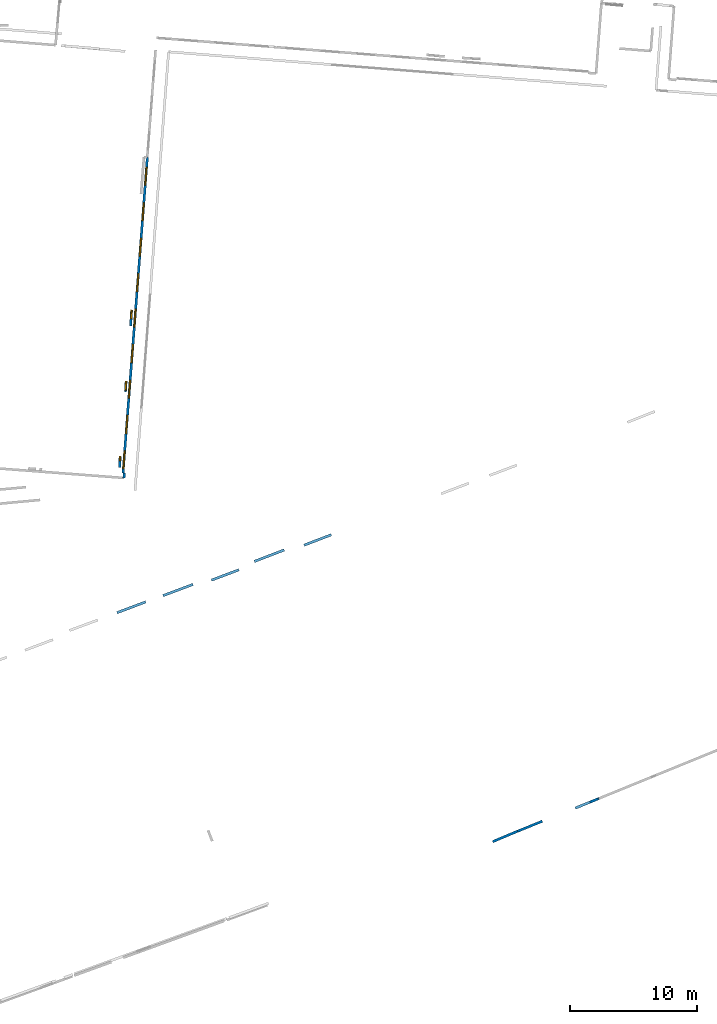
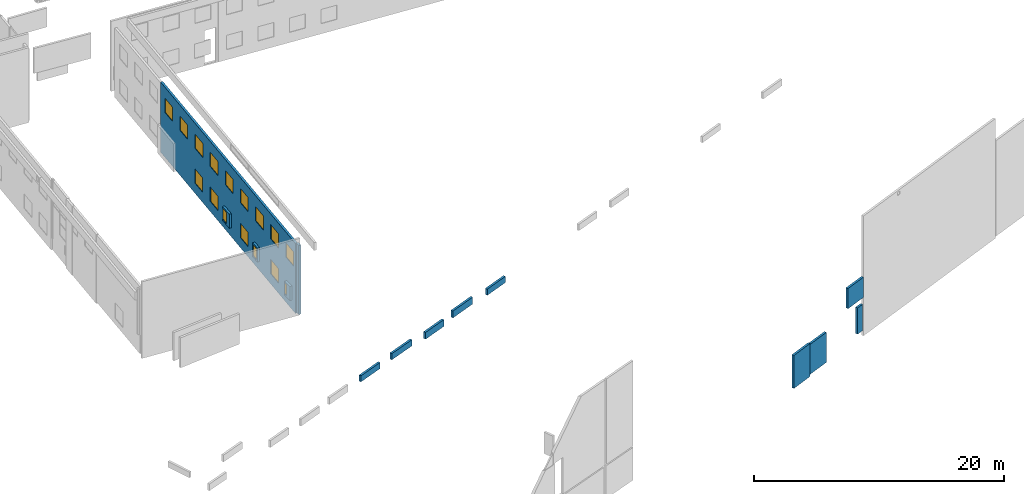
# One storey, part 2 of 27: 16 windows, 14 walls, 16 openings.
"""IFC2X3 building model written with IfcOpenShell, lengths in metres."""

import ifcopenshell
import ifcopenshell.guid

model = None  # the IFC model being written
_history = None  # IfcOwnerHistory: only IFC2X3 demands one
_inside = {}  # id of a spatial element -> (the spatial element, [elements in it])
_under = {}  # id of a project, library or spatial element -> (it, [spatial elements below it])
_declared = {}  # id of a project -> (the project, [libraries it declares])
_typed = {}  # id of a type object -> (the type object, [elements of that type])
_made_of = {}  # id of a material, layer set ... -> (it, [elements and type objects made of it])


def new_model(schema):
    """Start an empty IFC model of exactly this schema.

    Asked for "IFC4X3", IfcOpenShell would pick the latest addendum, in which some entities
    have other attributes; the version numbers below select the first issue.
    IFC2X3 requires an IfcOwnerHistory on every rooted entity: one is made here for all.
    """
    global model, _history
    if schema == "IFC4X3":
        model = ifcopenshell.file(schema_version=(4, 3, 0, 0))
    else:
        model = ifcopenshell.file(schema=schema)
    _inside.clear()
    _under.clear()
    _declared.clear()
    _typed.clear()
    _made_of.clear()
    _history = None
    if model.schema == "IFC2X3":
        org = make("IfcOrganization", Name="unknown")
        user = make(
            "IfcPersonAndOrganization",
            ThePerson=make("IfcPerson", FamilyName="unknown"),
            TheOrganization=org,
        )
        app = make(
            "IfcApplication",
            ApplicationDeveloper=org,
            Version="unknown",
            ApplicationFullName="unknown",
            ApplicationIdentifier="unknown",
        )
        _history = make(
            "IfcOwnerHistory",
            OwningUser=user,
            OwningApplication=app,
            ChangeAction="ADDED",
            CreationDate=0,
        )
    return model


def make(cls, **values):
    """One entity of the class cls with the attributes given. An attribute that is None is left unset."""
    return model.create_entity(
        cls, **{name: value for name, value in values.items() if value is not None}
    )


def entity(cls, *values):
    """Any entity or typed value of the class cls, its attributes in the order of the schema. None: left unset."""
    e = model.create_entity(cls)
    for i, value in enumerate(values):
        if value is not None:
            e[i] = value
    return e


def rooted(cls, **values):
    """An entity with a GlobalId (a new one), such as an element, a storey or a relation."""
    return make(cls, GlobalId=ifcopenshell.guid.new(), OwnerHistory=_history, **values)


def si_unit(unit_type, name, prefix=None):
    """IfcSIUnit, for example si_unit("LENGTHUNIT", "METRE", prefix="MILLI")."""
    return make("IfcSIUnit", UnitType=unit_type, Prefix=prefix, Name=name)


def converted_unit(unit_type, name, factor, base, dimensions=None, offset=None):
    """IfcConversionBasedUnit, such as the inch: factor (a typed value) times the base unit."""
    return make(
        "IfcConversionBasedUnit"
        if offset is None
        else "IfcConversionBasedUnitWithOffset",
        ConversionOffset=offset,
        Dimensions=None
        if dimensions is None
        else entity("IfcDimensionalExponents", *dimensions),
        UnitType=unit_type,
        Name=name,
        ConversionFactor=make(
            "IfcMeasureWithUnit", ValueComponent=factor, UnitComponent=base
        ),
    )


def derived_unit(unit_type, elements):
    """IfcDerivedUnit: a product of units, each with its exponent."""
    return make(
        "IfcDerivedUnit",
        Elements=[
            make("IfcDerivedUnitElement", Unit=unit, Exponent=power)
            for unit, power in elements
        ],
        UnitType=unit_type,
    )


def assignment(units):
    """IfcUnitAssignment: the units of a project."""
    return None if units is None else make("IfcUnitAssignment", Units=units)


def point(xyz):
    """IfcCartesianPoint."""
    return None if xyz is None else make("IfcCartesianPoint", Coordinates=xyz)


def direction(xyz):
    """IfcDirection."""
    return None if xyz is None else make("IfcDirection", DirectionRatios=xyz)


def frame(location, z_axis=None, x_axis=None):
    """IfcAxis2Placement3D, a coordinate frame: its origin and axes. An axis left out is left unset."""
    return make(
        "IfcAxis2Placement3D",
        Location=point(location),
        Axis=direction(z_axis),
        RefDirection=direction(x_axis),
    )


def frame_2d(location, x_axis=None):
    """IfcAxis2Placement2D, a coordinate frame in the plane: its origin and x axis."""
    return make(
        "IfcAxis2Placement2D", Location=point(location), RefDirection=direction(x_axis)
    )


def origin():
    """The frame at (0, 0, 0) with its axes left unset."""
    return frame((0.0, 0.0, 0.0))


def origin_2d_with_axis():
    """The frame at (0, 0) in the plane with the x axis (1, 0) written out."""
    return frame_2d((0.0, 0.0), x_axis=(1.0, 0.0))


def place(relative_to, where):
    """IfcLocalPlacement: puts the frame where relative to a parent placement (None: the world)."""
    return make(
        "IfcLocalPlacement", PlacementRelTo=relative_to, RelativePlacement=where
    )


def context(
    kind, dimensions, precision=None, world=None, true_north=None, identifier=None
):
    """IfcGeometricRepresentationContext, for example the 3D "Model" context."""
    return make(
        "IfcGeometricRepresentationContext",
        ContextIdentifier=identifier,
        ContextType=kind,
        CoordinateSpaceDimension=dimensions,
        Precision=precision,
        WorldCoordinateSystem=world,
        TrueNorth=true_north,
    )


def subcontext(parent, identifier, kind, view, scale=None):
    """IfcGeometricRepresentationSubContext, for example "Body" below "Model"."""
    return make(
        "IfcGeometricRepresentationSubContext",
        ContextIdentifier=identifier,
        ContextType=kind,
        ParentContext=parent,
        TargetScale=scale,
        TargetView=view,
    )


def project(units=None, contexts=None):
    """IfcProject with its units and contexts."""
    return rooted(
        "IfcProject",
        Name="project",
        RepresentationContexts=contexts,
        UnitsInContext=assignment(units),
    )


def spatial(cls, under=None, at=None, **own):
    """A site, building, storey or space (cls), placed at a placement, below another one or the project."""
    s = rooted(cls, ObjectPlacement=at, **own)
    if under is not None:
        _under.setdefault(under.id(), (under, []))[1].append(s)
    return s


def polyline(points):
    """IfcPolyline through the points."""
    return make("IfcPolyline", Points=[point(p) for p in points])


def profile(cls, at=None, kind="AREA", **sizes):
    """A parametric profile (cls). Its sizes go by their IFC names, for example OverallWidth=200.0."""
    return make(cls, ProfileType=kind, Position=at, **sizes)


def rectangle(**sizes):
    """IfcRectangleProfileDef."""
    return profile("IfcRectangleProfileDef", **sizes)


def outline(outer, holes=None, kind="AREA"):
    """IfcArbitraryClosedProfileDef: a profile drawn as a closed curve; with holes, ...WithVoids."""
    if holes is None:
        return make("IfcArbitraryClosedProfileDef", ProfileType=kind, OuterCurve=outer)
    return make(
        "IfcArbitraryProfileDefWithVoids",
        ProfileType=kind,
        OuterCurve=outer,
        InnerCurves=holes,
    )


def extrude(swept, where, along, depth):
    """IfcExtrudedAreaSolid: the profile swept, set in the frame where, extruded along a direction by depth."""
    return make(
        "IfcExtrudedAreaSolid",
        SweptArea=swept,
        Position=where,
        ExtrudedDirection=direction(along),
        Depth=depth,
    )


def shape(context_of_items, identifier, shape_type, items):
    """IfcShapeRepresentation: the items that make up one representation, for example the "Body"."""
    return make(
        "IfcShapeRepresentation",
        ContextOfItems=context_of_items,
        RepresentationIdentifier=identifier,
        RepresentationType=shape_type,
        Items=items,
    )


def source(mapping_origin, context_of_items, identifier, shape_type, items):
    """IfcRepresentationMap: a shape defined once, which mapped items show again and again."""
    return make(
        "IfcRepresentationMap",
        MappingOrigin=mapping_origin,
        MappedRepresentation=shape(context_of_items, identifier, shape_type, items),
    )


def transform(
    local_origin,
    x_axis=None,
    y_axis=None,
    z_axis=None,
    scale=None,
    scale2=None,
    scale3=None,
    uniform=True,
):
    """IfcCartesianTransformationOperator3D, or its non-uniform kind. x_axis, y_axis, z_axis: its Axis1, 2, 3."""
    if uniform:
        return make(
            "IfcCartesianTransformationOperator3D",
            Axis1=direction(x_axis),
            Axis2=direction(y_axis),
            LocalOrigin=point(local_origin),
            Scale=scale,
            Axis3=direction(z_axis),
        )
    return make(
        "IfcCartesianTransformationOperator3DnonUniform",
        Axis1=direction(x_axis),
        Axis2=direction(y_axis),
        LocalOrigin=point(local_origin),
        Scale=scale,
        Axis3=direction(z_axis),
        Scale2=scale2,
        Scale3=scale3,
    )


def mapped(mapping_source, mapping_target):
    """IfcMappedItem: shows the shape of a source again, moved by a transform."""
    return make(
        "IfcMappedItem", MappingSource=mapping_source, MappingTarget=mapping_target
    )


def material(Name=None, Category=None):
    """IfcMaterial."""
    return make("IfcMaterial", Name=Name, Category=Category)


def layer(
    of_material, thickness, ventilated=None, Name=None, Category=None, Priority=None
):
    """IfcMaterialLayer: one layer of a wall or slab, of a material (None: an air gap)."""
    return make(
        "IfcMaterialLayer",
        Material=of_material,
        LayerThickness=thickness,
        IsVentilated=ventilated,
        Name=Name,
        Category=Category,
        Priority=Priority,
    )


def layer_set(layers, Name=None):
    """IfcMaterialLayerSet."""
    return make("IfcMaterialLayerSet", MaterialLayers=layers, LayerSetName=Name)


def layer_usage(for_layer_set, set_direction, sense, offset, extent=None):
    """IfcMaterialLayerSetUsage: how a layer set lies in its element."""
    return make(
        "IfcMaterialLayerSetUsage",
        ForLayerSet=for_layer_set,
        LayerSetDirection=set_direction,
        DirectionSense=sense,
        OffsetFromReferenceLine=offset,
        ReferenceExtent=extent,
    )


def made_of(thing, what):
    """Note that an element or type object is made of a material, layer set ...; save() writes the relation."""
    if what is not None:
        _made_of.setdefault(what.id(), (what, []))[1].append(thing)
    return thing


def type_object(cls, material=None, **own):
    """A type object (cls), such as IfcWallType, which elements share."""
    return made_of(rooted(cls, **own), material)


def type_shapes(of_type, sources):
    """Give a type object the sources (RepresentationMaps) that its elements show as mapped items."""
    of_type.RepresentationMaps = sources


def element(
    cls,
    number,
    at=None,
    inside=None,
    cuts=None,
    type_object=None,
    material=None,
    context=None,
    identifier="Body",
    shape_type=None,
    held_by="IfcProductDefinitionShape",
    body=None,
    shapes=None,
    **own,
):
    """One element of the class cls, such as IfcWall. Its Tag is "e" and its number.

    at: its placement. inside: the storey or other place that contains it. cuts: it is an
    opening in that element (IfcRelVoidsElement). A single representation is given by context,
    identifier, shape_type and body (its items); several are given by shapes. held_by: the class
    of the entity that holds the representations. save() writes the other relations.
    """
    e = rooted(cls, Tag="e%d" % number, ObjectPlacement=at, **own)
    if body is not None:
        shapes = [shape(context, identifier, shape_type, body)]
    if shapes is not None:
        e.Representation = make(held_by, Representations=shapes)
    if inside is not None:
        _inside.setdefault(inside.id(), (inside, []))[1].append(e)
    if cuts is not None:
        rooted(
            "IfcRelVoidsElement", RelatingBuildingElement=cuts, RelatedOpeningElement=e
        )
    if type_object is not None:
        _typed.setdefault(type_object.id(), (type_object, []))[1].append(e)
    return made_of(e, material)


def fill(opening, filler):
    """IfcRelFillsElement: the door or window that sits in an opening."""
    return rooted(
        "IfcRelFillsElement",
        RelatingOpeningElement=opening,
        RelatedBuildingElement=filler,
    )


def aggregate(whole, parts):
    """IfcRelAggregates: a whole, such as a stair, and the parts it consists of."""
    return rooted("IfcRelAggregates", RelatingObject=whole, RelatedObjects=parts)


def save(model, path):
    """Write the relations noted so far, then the file.

    IfcRelAggregates (storeys below a building ...), IfcRelContainedInSpatialStructure (elements
    in a storey), IfcRelDefinesByType, IfcRelAssociatesMaterial and IfcRelDeclares: one each for
    every whole, place, type object, material and project.
    """
    for whole, parts in _under.values():
        aggregate(whole, parts)
    for where, things in _inside.values():
        rooted(
            "IfcRelContainedInSpatialStructure",
            RelatedElements=things,
            RelatingStructure=where,
        )
    for kind, things in _typed.values():
        rooted("IfcRelDefinesByType", RelatedObjects=things, RelatingType=kind)
    for what, things in _made_of.values():
        rooted("IfcRelAssociatesMaterial", RelatedObjects=things, RelatingMaterial=what)
    for by, libraries in _declared.values():
        rooted("IfcRelDeclares", RelatingContext=by, RelatedDefinitions=libraries)
    model.write(path)


model = new_model("IFC2X3")

# Units and contexts
model_context = context("Model", 3, precision=1e-05, world=origin(), true_north=direction((0.0, 1.0)))
body_context = subcontext(model_context, "Body", "Model", "MODEL_VIEW")
ifc_project = project(units=[si_unit("LENGTHUNIT", "METRE"), si_unit("AREAUNIT", "SQUARE_METRE"), si_unit("VOLUMEUNIT", "CUBIC_METRE"), converted_unit("PLANEANGLEUNIT", "DEGREE", entity("IfcRatioMeasure", 0.0174532925199433), si_unit("PLANEANGLEUNIT", "RADIAN"), dimensions=[0, 0, 0, 0, 0, 0, 0]), si_unit("MASSUNIT", "GRAM", prefix="KILO"), derived_unit("MASSDENSITYUNIT", [(si_unit("MASSUNIT", "GRAM", prefix="KILO"), 1), (si_unit("LENGTHUNIT", "METRE"), -3)]), derived_unit("MOMENTOFINERTIAUNIT", [(si_unit("LENGTHUNIT", "METRE"), 4)]), si_unit("TIMEUNIT", "SECOND"), si_unit("FREQUENCYUNIT", "HERTZ"), si_unit("THERMODYNAMICTEMPERATUREUNIT", "DEGREE_CELSIUS"), derived_unit("THERMALTRANSMITTANCEUNIT", [(si_unit("MASSUNIT", "GRAM", prefix="KILO"), 1), (si_unit("THERMODYNAMICTEMPERATUREUNIT", "KELVIN"), -1), (si_unit("TIMEUNIT", "SECOND"), -3)]), derived_unit("VOLUMETRICFLOWRATEUNIT", [(si_unit("LENGTHUNIT", "METRE"), 3), (si_unit("TIMEUNIT", "SECOND"), -1)]), si_unit("ELECTRICCURRENTUNIT", "AMPERE"), si_unit("ELECTRICVOLTAGEUNIT", "VOLT"), si_unit("POWERUNIT", "WATT"), si_unit("FORCEUNIT", "NEWTON", prefix="KILO"), si_unit("ILLUMINANCEUNIT", "LUX"), si_unit("LUMINOUSFLUXUNIT", "LUMEN"), si_unit("LUMINOUSINTENSITYUNIT", "CANDELA"), derived_unit("USERDEFINED", [(si_unit("MASSUNIT", "GRAM", prefix="KILO"), -1), (si_unit("LENGTHUNIT", "METRE"), -2), (si_unit("TIMEUNIT", "SECOND"), 3), (si_unit("LUMINOUSFLUXUNIT", "LUMEN"), 1)]), derived_unit("LINEARVELOCITYUNIT", [(si_unit("LENGTHUNIT", "METRE"), 1), (si_unit("TIMEUNIT", "SECOND"), -1)]), si_unit("PRESSUREUNIT", "PASCAL"), derived_unit("USERDEFINED", [(si_unit("LENGTHUNIT", "METRE"), -2), (si_unit("MASSUNIT", "GRAM", prefix="KILO"), 1), (si_unit("TIMEUNIT", "SECOND"), -2)]), derived_unit("LINEARFORCEUNIT", [(si_unit("MASSUNIT", "GRAM", prefix="KILO"), 1), (si_unit("LENGTHUNIT", "METRE"), 1), (si_unit("TIMEUNIT", "SECOND"), -2), (si_unit("LENGTHUNIT", "METRE"), -1)]), derived_unit("PLANARFORCEUNIT", [(si_unit("MASSUNIT", "GRAM", prefix="KILO"), 1), (si_unit("LENGTHUNIT", "METRE"), 1), (si_unit("TIMEUNIT", "SECOND"), -2), (si_unit("LENGTHUNIT", "METRE"), -2)])], contexts=[model_context])

# Site, building, storey
placement_1 = place(None, origin())
site = spatial("IfcSite", under=ifc_project, at=placement_1, CompositionType="ELEMENT")
building = spatial("IfcBuilding", under=site, at=placement_1, CompositionType="ELEMENT")
storey_placement = place(placement_1, frame((0.0, 0.0, -61.043098449707)))
storey = spatial("IfcBuildingStorey", under=building, at=storey_placement, Name="level_-61.043098", CompositionType="ELEMENT", Elevation=-61.043098449707)

# Wall, opening, window
ifc_material_1 = material(Name="Default wall")
ifc_layer = layer(ifc_material_1, 0.2)
ifc_layer_set = layer_set([ifc_layer], Name="wall_thickness_0.2000")
ifc_layer_usage = layer_usage(ifc_layer_set, "AXIS2", "POSITIVE", -0.1)
wall_type = type_object("IfcWallType", Name="wall_thickness_0.2000", PredefinedType="STANDARD", material=ifc_layer_set)
placement_2 = place(placement_1, frame((0.0, 0.0, -59.9867630004883)))
wall_1_placement = place(placement_2, frame((-73.577877605384, -34.6902653634278, 0.0), z_axis=(0.0, 0.0, 1.0), x_axis=(-0.0637069196678718, -0.997968651003843, 0.0)))
wall_1 = element("IfcWallStandardCase", 1, at=wall_1_placement, inside=storey, type_object=wall_type, material=ifc_layer_usage, Name="Wall:119", ObjectType="Wall", context=body_context, shape_type="SweptSolid", body=[
    extrude(outline(polyline([(1.24260595346557, -0.1), (1.24260595346557, 0.1), (0.0, 0.1), (0.0, -0.1), (1.24260595346557, -0.1)])), origin(), (0.0, 0.0, 1.0), 1.37465286254883),
])
opening_1_placement = place(wall_1_placement, frame((-0.00739262793470002, -0.1, 0.142116546630859)))
opening_1 = element("IfcOpeningElement", 2, at=opening_1_placement, cuts=wall_1, Name="Opening : 700 x 1080 : 1", ObjectType="Opening", context=body_context, shape_type="SweptSolid", body=[
    extrude(rectangle(XDim=0.7, YDim=1.08, at=frame_2d((0.54, 0.35), x_axis=(0.0, 1.0))), frame((0.0, 0.0, 0.0), z_axis=(0.0, 1.0, 0.0), x_axis=(0.0, 0.0, 1.0)), (0.0, 0.0, 1.0), 0.2),
])
ifc_material_2 = material(Name="Window Default")
window_style_1 = type_object("IfcWindowStyle", Name="Window : 700 x 1080mm", ConstructionType="NOTDEFINED", OperationType="NOTDEFINED", ParameterTakesPrecedence=False, Sizeable=False, material=ifc_material_2)
shared_shape_1 = source(origin(), body_context, "Body", "SweptSolid", [
    extrude(rectangle(XDim=0.1, YDim=0.7, at=origin_2d_with_axis()), frame((0.35, 0.1, 0.0), z_axis=(0.0, 0.0, 1.0), x_axis=(0.0, 1.0, 0.0)), (0.0, 0.0, 1.0), 1.08),
])
type_shapes(window_style_1, [shared_shape_1])
window_1_placement = place(opening_1_placement, origin())
window_1 = element("IfcWindow", 3, at=window_1_placement, inside=storey, type_object=window_style_1, Name="Window : 700 x 1080mm : 0", ObjectType="Window : 700 x 1080mm", OverallHeight=1.08, OverallWidth=0.7, context=body_context, shape_type="MappedRepresentation", body=[
    mapped(shared_shape_1, transform((0.0, 0.0, 0.0), scale=1.0)),
])
fill(opening_1, window_1)

# Walls
placement_3 = place(placement_1, frame((0.0, 0.0, -60.8194160461426)))
wall_2_placement = place(placement_3, frame((-60.0052122339604, -53.1964125713586, 0.0), z_axis=(0.0, 0.0, 1.0), x_axis=(0.933737242207099, 0.357959163195304, 0.0)))
element("IfcWallStandardCase", 4, at=wall_2_placement, inside=storey, type_object=wall_type, material=ifc_layer_usage, Name="Wall:588", ObjectType="Wall", context=body_context, shape_type="SweptSolid", body=[
    extrude(outline(polyline([(2.29376846264763, -0.1), (2.29376846264763, 0.1), (0.0, 0.1), (0.0, -0.1), (2.29376846264763, -0.1)])), origin(), (0.0, 0.0, 1.0), 0.601425170898438),
])
placement_4 = place(placement_1, frame((0.0, 0.0, -60.9578857421875)))
wall_3_placement = place(placement_4, frame((-43.1991331559404, -75.7077910037415, 0.0), z_axis=(0.0, 0.0, 1.0), x_axis=(-0.921446324597061, -0.388505689645039, 0.0)))
element("IfcWallStandardCase", 5, at=wall_3_placement, inside=storey, type_object=wall_type, material=ifc_layer_usage, Name="Wall:705", ObjectType="Wall", context=body_context, shape_type="SweptSolid", body=[
    extrude(outline(polyline([(2.12596789332282, -0.1), (2.12596789332282, 0.1), (0.0, 0.1), (0.0, -0.1), (2.12596789332282, -0.1)])), origin(), (0.0, 0.0, 1.0), 3.22220230102539),
])
placement_5 = place(placement_1, frame((0.0, 0.0, -60.7575225830078)))
wall_4_placement = place(placement_5, frame((-43.1973078220014, -75.714885491394, 0.0), z_axis=(0.0, 0.0, 1.0), x_axis=(0.925557780960513, 0.378606384129285, 0.0)))
element("IfcWallStandardCase", 6, at=wall_4_placement, inside=storey, type_object=wall_type, material=ifc_layer_usage, Name="Wall:882", ObjectType="Wall", context=body_context, shape_type="SweptSolid", body=[
    extrude(outline(polyline([(2.10500030147994, -0.1), (2.10500030147994, 0.1), (0.0, 0.1), (0.0, -0.1), (2.10500030147994, -0.1)])), origin(), (0.0, 0.0, 1.0), 2.92899703979492),
])
placement_6 = place(placement_1, frame((0.0, 0.0, -60.233528137207)))
wall_5_placement = place(placement_6, frame((-37.495614404162, -73.4184051973955, 0.0), z_axis=(0.0, 0.0, 1.0), x_axis=(0.925839350069249, 0.377917316172931, 0.0)))
element("IfcWallStandardCase", 7, at=wall_5_placement, inside=storey, type_object=wall_type, material=ifc_layer_usage, Name="Wall:906", ObjectType="Wall", context=body_context, shape_type="SweptSolid", body=[
    extrude(outline(polyline([(0.669999322251911, -0.1), (0.669999322251911, 0.1), (0.0, 0.1), (0.0, -0.1), (0.669999322251911, -0.1)])), origin(), (0.0, 0.0, 1.0), 2.55500030517578),
])
placement_7 = place(placement_1, frame((0.0, 0.0, -57.0585250854492)))
wall_6_placement = place(placement_7, frame((-38.6482900328241, -73.8889099581377, 0.0), z_axis=(0.0, 0.0, 1.0), x_axis=(0.925840684444771, 0.377914047141461, 0.0)))
element("IfcWallStandardCase", 8, at=wall_6_placement, inside=storey, type_object=wall_type, material=ifc_layer_usage, Name="Wall:916", ObjectType="Wall", context=body_context, shape_type="SweptSolid", body=[
    extrude(outline(polyline([(2.01181210112061, -0.1), (2.01181210112061, 0.1), (0.0, 0.1), (0.0, -0.1), (2.01181210112061, -0.1)])), origin(), (0.0, 0.0, 1.0), 1.97235107421875),
])
placement_8 = place(placement_1, frame((0.0, 0.0, -60.8847198486328)))
wall_7_placement = place(placement_8, frame((-63.9128794122025, -54.4720646888531, 0.0), z_axis=(0.0, 0.0, 1.0), x_axis=(0.933573872584368, 0.358385022605335, 0.0)))
element("IfcWallStandardCase", 9, at=wall_7_placement, inside=storey, type_object=wall_type, material=ifc_layer_usage, Name="Wall:937", ObjectType="Wall", context=body_context, shape_type="SweptSolid", body=[
    extrude(outline(polyline([(2.51800765190407, -0.1), (2.51800765190407, 0.1), (0.0, 0.1), (0.0, -0.1), (2.51800765190407, -0.1)])), origin(), (0.0, 0.0, 1.0), 0.666728973388672),
])

# Wall, opening, window
placement_9 = place(placement_1, frame((0.0, 0.0, -59.9867630004883)))
wall_8_placement = place(placement_9, frame((-74.4896470838547, -46.1995110944796, 0.0), z_axis=(0.0, 0.0, 1.0), x_axis=(-0.0134034588731554, -0.999910169610368, 0.0)))
wall_8 = element("IfcWallStandardCase", 10, at=wall_8_placement, inside=storey, type_object=wall_type, material=ifc_layer_usage, Name="Wall:941", ObjectType="Wall", context=body_context, shape_type="SweptSolid", body=[
    extrude(outline(polyline([(0.88000001021645, -0.1), (0.88000001021645, 0.1), (0.0, 0.1), (0.0, -0.1), (0.88000001021645, -0.1)])), origin(), (0.0, 0.0, 1.0), 1.37465286254883),
])
opening_2_placement = place(wall_8_placement, frame((0.00500153927264296, -0.1, 0.157958984375)))
opening_2 = element("IfcOpeningElement", 11, at=opening_2_placement, cuts=wall_8, Name="Opening : 355 x 1075 : 109", ObjectType="Opening", context=body_context, shape_type="SweptSolid", body=[
    extrude(rectangle(XDim=0.355, YDim=1.075, at=frame_2d((0.5375, 0.1775), x_axis=(0.0, 1.0))), frame((0.0, 0.0, 0.0), z_axis=(0.0, 1.0, 0.0), x_axis=(0.0, 0.0, 1.0)), (0.0, 0.0, 1.0), 0.2),
])
window_style_2 = type_object("IfcWindowStyle", Name="Window : 355 x 1075mm", ConstructionType="NOTDEFINED", OperationType="NOTDEFINED", ParameterTakesPrecedence=False, Sizeable=False, material=ifc_material_2)
shared_shape_2 = source(origin(), body_context, "Body", "SweptSolid", [
    extrude(rectangle(XDim=0.1, YDim=0.355, at=origin_2d_with_axis()), frame((0.1775, 0.1, 0.0), z_axis=(0.0, 0.0, 1.0), x_axis=(0.0, 1.0, 0.0)), (0.0, 0.0, 1.0), 1.075),
])
type_shapes(window_style_2, [shared_shape_2])
window_2_placement = place(opening_2_placement, origin())
window_2 = element("IfcWindow", 12, at=window_2_placement, inside=storey, type_object=window_style_2, Name="Window : 355 x 1075mm : 97", ObjectType="Window : 355 x 1075mm", OverallHeight=1.075, OverallWidth=0.355, context=body_context, shape_type="MappedRepresentation", body=[
    mapped(shared_shape_2, transform((0.0, 0.0, 0.0), scale=1.0)),
])
fill(opening_2, window_2)

# Wall
placement_10 = place(placement_1, frame((0.0, 0.0, -60.8194160461426)))
wall_9_placement = place(placement_10, frame((-71.1079782509342, -57.1679905133707, 0.0), z_axis=(0.0, 0.0, 1.0), x_axis=(0.936481373175218, 0.35071731878517, 0.0)))
element("IfcWallStandardCase", 13, at=wall_9_placement, inside=storey, type_object=wall_type, material=ifc_layer_usage, Name="Wall:1267", ObjectType="Wall", context=body_context, shape_type="SweptSolid", body=[
    extrude(outline(polyline([(2.52421074298415, -0.1), (2.52421074298415, 0.1), (0.0, 0.1), (0.0, -0.1), (2.52421074298415, -0.1)])), origin(), (0.0, 0.0, 1.0), 0.601425170898438),
])

# Wall, openings, windows
wall_10_placement = place(storey_placement, frame((-72.3394733440847, -22.6585245071925, 0.0), z_axis=(0.0, 0.0, 1.0), x_axis=(-0.0768377471232908, -0.997043610188149, 0.0)))
wall_10 = element("IfcWallStandardCase", 14, at=wall_10_placement, inside=storey, type_object=wall_type, material=ifc_layer_usage, Name="Wall:1355", ObjectType="Wall", context=body_context, shape_type="SweptSolid", body=[
    extrude(outline(polyline([(24.9366585030375, -0.1), (24.9366585030375, 0.1), (0.0, 0.1), (0.0, -0.1), (24.9366585030375, -0.1)])), origin(), (0.0, 0.0, 1.0), 6.83392333984375),
])
opening_3_placement = place(wall_10_placement, frame((9.19336267719424, -0.1, 0.993156433105469)))
opening_3 = element("IfcOpeningElement", 15, at=opening_3_placement, cuts=wall_10, Name="Opening : 1410 x 1395 : 215", ObjectType="Opening", context=body_context, shape_type="SweptSolid", body=[
    extrude(rectangle(XDim=1.41, YDim=1.395, at=frame_2d((0.6975, 0.705), x_axis=(0.0, 1.0))), frame((0.0, 0.0, 0.0), z_axis=(0.0, 1.0, 0.0), x_axis=(0.0, 0.0, 1.0)), (0.0, 0.0, 1.0), 0.2),
])
opening_4_placement = place(wall_10_placement, frame((20.3816613197451, -0.1, 4.40315628051758)))
opening_4 = element("IfcOpeningElement", 16, at=opening_4_placement, cuts=wall_10, Name="Opening : 1430 x 1390 : 216", ObjectType="Opening", context=body_context, shape_type="SweptSolid", body=[
    extrude(rectangle(XDim=1.43, YDim=1.39, at=frame_2d((0.695, 0.715), x_axis=(0.0, 1.0))), frame((0.0, 0.0, 0.0), z_axis=(0.0, 1.0, 0.0), x_axis=(0.0, 0.0, 1.0)), (0.0, 0.0, 1.0), 0.2),
])
opening_5_placement = place(wall_10_placement, frame((23.1766598391232, -0.1, 4.40815734863281)))
opening_5 = element("IfcOpeningElement", 17, at=opening_5_placement, cuts=wall_10, Name="Opening : 1420 x 1385 : 217", ObjectType="Opening", context=body_context, shape_type="SweptSolid", body=[
    extrude(rectangle(XDim=1.42, YDim=1.385, at=frame_2d((0.6925, 0.71), x_axis=(0.0, 1.0))), frame((0.0, 0.0, 0.0), z_axis=(0.0, 1.0, 0.0), x_axis=(0.0, 0.0, 1.0)), (0.0, 0.0, 1.0), 0.2),
])
opening_6_placement = place(wall_10_placement, frame((3.59666028237242, -0.1, 4.38815689086914)))
opening_6 = element("IfcOpeningElement", 18, at=opening_6_placement, cuts=wall_10, Name="Opening : 1410 x 1395 : 218", ObjectType="Opening", context=body_context, shape_type="SweptSolid", body=[
    extrude(rectangle(XDim=1.41, YDim=1.395, at=frame_2d((0.6975, 0.705), x_axis=(0.0, 1.0))), frame((0.0, 0.0, 0.0), z_axis=(0.0, 1.0, 0.0), x_axis=(0.0, 0.0, 1.0)), (0.0, 0.0, 1.0), 0.2),
])
opening_7_placement = place(wall_10_placement, frame((9.1816607439435, -0.1, 4.39315795898438)))
opening_7 = element("IfcOpeningElement", 19, at=opening_7_placement, cuts=wall_10, Name="Opening : 1420 x 1390 : 219", ObjectType="Opening", context=body_context, shape_type="SweptSolid", body=[
    extrude(rectangle(XDim=1.42, YDim=1.39, at=frame_2d((0.695, 0.71), x_axis=(0.0, 1.0))), frame((0.0, 0.0, 0.0), z_axis=(0.0, 1.0, 0.0), x_axis=(0.0, 0.0, 1.0)), (0.0, 0.0, 1.0), 0.2),
])
opening_8_placement = place(wall_10_placement, frame((11.9816596439263, -0.1, 4.39315795898438)))
opening_8 = element("IfcOpeningElement", 20, at=opening_8_placement, cuts=wall_10, Name="Opening : 1420 x 1390 : 220", ObjectType="Opening", context=body_context, shape_type="SweptSolid", body=[
    extrude(rectangle(XDim=1.42, YDim=1.39, at=frame_2d((0.695, 0.71), x_axis=(0.0, 1.0))), frame((0.0, 0.0, 0.0), z_axis=(0.0, 1.0, 0.0), x_axis=(0.0, 0.0, 1.0)), (0.0, 0.0, 1.0), 0.2),
])
opening_9_placement = place(wall_10_placement, frame((14.8016612387787, -0.1, 4.39315795898438)))
opening_9 = element("IfcOpeningElement", 21, at=opening_9_placement, cuts=wall_10, Name="Opening : 1415 x 1395 : 221", ObjectType="Opening", context=body_context, shape_type="SweptSolid", body=[
    extrude(rectangle(XDim=1.415, YDim=1.395, at=frame_2d((0.6975, 0.7075), x_axis=(0.0, 1.0))), frame((0.0, 0.0, 0.0), z_axis=(0.0, 1.0, 0.0), x_axis=(0.0, 0.0, 1.0)), (0.0, 0.0, 1.0), 0.2),
])
opening_10_placement = place(wall_10_placement, frame((17.5916593775521, -0.1, 4.38815689086914)))
opening_10 = element("IfcOpeningElement", 22, at=opening_10_placement, cuts=wall_10, Name="Opening : 1420 x 1395 : 222", ObjectType="Opening", context=body_context, shape_type="SweptSolid", body=[
    extrude(rectangle(XDim=1.42, YDim=1.395, at=frame_2d((0.6975, 0.71), x_axis=(0.0, 1.0))), frame((0.0, 0.0, 0.0), z_axis=(0.0, 1.0, 0.0), x_axis=(0.0, 0.0, 1.0)), (0.0, 0.0, 1.0), 0.2),
])
opening_11_placement = place(wall_10_placement, frame((0.801659861284541, -0.1, 4.37815856933594)))
opening_11 = element("IfcOpeningElement", 23, at=opening_11_placement, cuts=wall_10, Name="Opening : 1410 x 1395 : 223", ObjectType="Opening", context=body_context, shape_type="SweptSolid", body=[
    extrude(rectangle(XDim=1.41, YDim=1.395, at=frame_2d((0.6975, 0.705), x_axis=(0.0, 1.0))), frame((0.0, 0.0, 0.0), z_axis=(0.0, 1.0, 0.0), x_axis=(0.0, 0.0, 1.0)), (0.0, 0.0, 1.0), 0.2),
])
opening_12_placement = place(wall_10_placement, frame((6.39166260517006, -0.1, 4.38815689086914)))
opening_12 = element("IfcOpeningElement", 24, at=opening_12_placement, cuts=wall_10, Name="Opening : 1415 x 1390 : 224", ObjectType="Opening", context=body_context, shape_type="SweptSolid", body=[
    extrude(rectangle(XDim=1.415, YDim=1.39, at=frame_2d((0.695, 0.7075), x_axis=(0.0, 1.0))), frame((0.0, 0.0, 0.0), z_axis=(0.0, 1.0, 0.0), x_axis=(0.0, 0.0, 1.0)), (0.0, 0.0, 1.0), 0.2),
])
opening_13_placement = place(wall_10_placement, frame((20.3816613197451, -0.1, 0.9881591796875)))
opening_13 = element("IfcOpeningElement", 25, at=opening_13_placement, cuts=wall_10, Name="Opening : 1430 x 1405 : 225", ObjectType="Opening", context=body_context, shape_type="SweptSolid", body=[
    extrude(rectangle(XDim=1.43, YDim=1.405, at=frame_2d((0.7025, 0.715), x_axis=(0.0, 1.0))), frame((0.0, 0.0, 0.0), z_axis=(0.0, 1.0, 0.0), x_axis=(0.0, 0.0, 1.0)), (0.0, 0.0, 1.0), 0.2),
])
opening_14_placement = place(wall_10_placement, frame((6.38166125773525, -0.1, 0.983158111572266)))
opening_14 = element("IfcOpeningElement", 26, at=opening_14_placement, cuts=wall_10, Name="Opening : 1415 x 1395 : 226", ObjectType="Opening", context=body_context, shape_type="SweptSolid", body=[
    extrude(rectangle(XDim=1.415, YDim=1.395, at=frame_2d((0.6975, 0.7075), x_axis=(0.0, 1.0))), frame((0.0, 0.0, 0.0), z_axis=(0.0, 1.0, 0.0), x_axis=(0.0, 0.0, 1.0)), (0.0, 0.0, 1.0), 0.2),
])
opening_15_placement = place(wall_10_placement, frame((14.7816591301345, -0.1, 0.983158111572266)))
opening_15 = element("IfcOpeningElement", 27, at=opening_15_placement, cuts=wall_10, Name="Opening : 1415 x 1395 : 227", ObjectType="Opening", context=body_context, shape_type="SweptSolid", body=[
    extrude(rectangle(XDim=1.415, YDim=1.395, at=frame_2d((0.6975, 0.7075), x_axis=(0.0, 1.0))), frame((0.0, 0.0, 0.0), z_axis=(0.0, 1.0, 0.0), x_axis=(0.0, 0.0, 1.0)), (0.0, 0.0, 1.0), 0.2),
])
window_style_3 = type_object("IfcWindowStyle", Name="Window : 1420 x 1385mm", ConstructionType="NOTDEFINED", OperationType="NOTDEFINED", ParameterTakesPrecedence=False, Sizeable=False, material=ifc_material_2)
shared_shape_3 = source(origin(), body_context, "Body", "SweptSolid", [
    extrude(rectangle(XDim=0.1, YDim=1.42, at=origin_2d_with_axis()), frame((0.71, 0.1, 0.0), z_axis=(0.0, 0.0, 1.0), x_axis=(0.0, 1.0, 0.0)), (0.0, 0.0, 1.0), 1.385),
])
type_shapes(window_style_3, [shared_shape_3])
window_3_placement = place(opening_5_placement, origin())
window_3 = element("IfcWindow", 28, at=window_3_placement, inside=storey, type_object=window_style_3, Name="Window : 1420 x 1385mm : 200", ObjectType="Window : 1420 x 1385mm", OverallHeight=1.385, OverallWidth=1.42, context=body_context, shape_type="MappedRepresentation", body=[
    mapped(shared_shape_3, transform((0.0, 0.0, 0.0), scale=1.0)),
])
fill(opening_5, window_3)
window_style_4 = type_object("IfcWindowStyle", Name="Window : 1420 x 1390mm", ConstructionType="NOTDEFINED", OperationType="NOTDEFINED", ParameterTakesPrecedence=False, Sizeable=False, material=ifc_material_2)
shared_shape_4 = source(origin(), body_context, "Body", "SweptSolid", [
    extrude(rectangle(XDim=0.1, YDim=1.42, at=origin_2d_with_axis()), frame((0.71, 0.1, 0.0), z_axis=(0.0, 0.0, 1.0), x_axis=(0.0, 1.0, 0.0)), (0.0, 0.0, 1.0), 1.39),
])
type_shapes(window_style_4, [shared_shape_4])
window_4_placement = place(opening_7_placement, origin())
window_4 = element("IfcWindow", 29, at=window_4_placement, inside=storey, type_object=window_style_4, Name="Window : 1420 x 1390mm : 202", ObjectType="Window : 1420 x 1390mm", OverallHeight=1.39, OverallWidth=1.42, context=body_context, shape_type="MappedRepresentation", body=[
    mapped(shared_shape_4, transform((0.0, 0.0, 0.0), scale=1.0)),
])
fill(opening_7, window_4)
window_5_placement = place(opening_8_placement, origin())
window_5 = element("IfcWindow", 30, at=window_5_placement, inside=storey, type_object=window_style_4, Name="Window : 1420 x 1390mm : 203", ObjectType="Window : 1420 x 1390mm", OverallHeight=1.39, OverallWidth=1.42, context=body_context, shape_type="MappedRepresentation", body=[
    mapped(shared_shape_4, transform((0.0, 0.0, 0.0), scale=1.0)),
])
fill(opening_8, window_5)
window_style_5 = type_object("IfcWindowStyle", Name="Window : 1430 x 1390mm", ConstructionType="NOTDEFINED", OperationType="NOTDEFINED", ParameterTakesPrecedence=False, Sizeable=False, material=ifc_material_2)
shared_shape_5 = source(origin(), body_context, "Body", "SweptSolid", [
    extrude(rectangle(XDim=0.1, YDim=1.43, at=origin_2d_with_axis()), frame((0.715, 0.1, 0.0), z_axis=(0.0, 0.0, 1.0), x_axis=(0.0, 1.0, 0.0)), (0.0, 0.0, 1.0), 1.39),
])
type_shapes(window_style_5, [shared_shape_5])
window_6_placement = place(opening_4_placement, origin())
window_6 = element("IfcWindow", 31, at=window_6_placement, inside=storey, type_object=window_style_5, Name="Window : 1430 x 1390mm : 199", ObjectType="Window : 1430 x 1390mm", OverallHeight=1.39, OverallWidth=1.43, context=body_context, shape_type="MappedRepresentation", body=[
    mapped(shared_shape_5, transform((0.0, 0.0, 0.0), scale=1.0)),
])
fill(opening_4, window_6)
window_style_6 = type_object("IfcWindowStyle", Name="Window : 1420 x 1395mm", ConstructionType="NOTDEFINED", OperationType="NOTDEFINED", ParameterTakesPrecedence=False, Sizeable=False, material=ifc_material_2)
shared_shape_6 = source(origin(), body_context, "Body", "SweptSolid", [
    extrude(rectangle(XDim=0.1, YDim=1.42, at=origin_2d_with_axis()), frame((0.71, 0.1, 0.0), z_axis=(0.0, 0.0, 1.0), x_axis=(0.0, 1.0, 0.0)), (0.0, 0.0, 1.0), 1.395),
])
type_shapes(window_style_6, [shared_shape_6])
window_7_placement = place(opening_10_placement, origin())
window_7 = element("IfcWindow", 32, at=window_7_placement, inside=storey, type_object=window_style_6, Name="Window : 1420 x 1395mm : 205", ObjectType="Window : 1420 x 1395mm", OverallHeight=1.395, OverallWidth=1.42, context=body_context, shape_type="MappedRepresentation", body=[
    mapped(shared_shape_6, transform((0.0, 0.0, 0.0), scale=1.0)),
])
fill(opening_10, window_7)
window_style_7 = type_object("IfcWindowStyle", Name="Window : 1410 x 1395mm", ConstructionType="NOTDEFINED", OperationType="NOTDEFINED", ParameterTakesPrecedence=False, Sizeable=False, material=ifc_material_2)
shared_shape_7 = source(origin(), body_context, "Body", "SweptSolid", [
    extrude(rectangle(XDim=0.1, YDim=1.41, at=origin_2d_with_axis()), frame((0.705, 0.1, 0.0), z_axis=(0.0, 0.0, 1.0), x_axis=(0.0, 1.0, 0.0)), (0.0, 0.0, 1.0), 1.395),
])
type_shapes(window_style_7, [shared_shape_7])
window_8_placement = place(opening_3_placement, origin())
window_8 = element("IfcWindow", 33, at=window_8_placement, inside=storey, type_object=window_style_7, Name="Window : 1410 x 1395mm : 198", ObjectType="Window : 1410 x 1395mm", OverallHeight=1.395, OverallWidth=1.41, context=body_context, shape_type="MappedRepresentation", body=[
    mapped(shared_shape_7, transform((0.0, 0.0, 0.0), scale=1.0)),
])
fill(opening_3, window_8)
window_9_placement = place(opening_6_placement, origin())
window_9 = element("IfcWindow", 34, at=window_9_placement, inside=storey, type_object=window_style_7, Name="Window : 1410 x 1395mm : 201", ObjectType="Window : 1410 x 1395mm", OverallHeight=1.395, OverallWidth=1.41, context=body_context, shape_type="MappedRepresentation", body=[
    mapped(shared_shape_7, transform((0.0, 0.0, 0.0), scale=1.0)),
])
fill(opening_6, window_9)
window_10_placement = place(opening_11_placement, origin())
window_10 = element("IfcWindow", 35, at=window_10_placement, inside=storey, type_object=window_style_7, Name="Window : 1410 x 1395mm : 206", ObjectType="Window : 1410 x 1395mm", OverallHeight=1.395, OverallWidth=1.41, context=body_context, shape_type="MappedRepresentation", body=[
    mapped(shared_shape_7, transform((0.0, 0.0, 0.0), scale=1.0)),
])
fill(opening_11, window_10)
window_style_8 = type_object("IfcWindowStyle", Name="Window : 1415 x 1395mm", ConstructionType="NOTDEFINED", OperationType="NOTDEFINED", ParameterTakesPrecedence=False, Sizeable=False, material=ifc_material_2)
shared_shape_8 = source(origin(), body_context, "Body", "SweptSolid", [
    extrude(rectangle(XDim=0.1, YDim=1.415, at=origin_2d_with_axis()), frame((0.7075, 0.1, 0.0), z_axis=(0.0, 0.0, 1.0), x_axis=(0.0, 1.0, 0.0)), (0.0, 0.0, 1.0), 1.395),
])
type_shapes(window_style_8, [shared_shape_8])
window_11_placement = place(opening_9_placement, origin())
window_11 = element("IfcWindow", 36, at=window_11_placement, inside=storey, type_object=window_style_8, Name="Window : 1415 x 1395mm : 204", ObjectType="Window : 1415 x 1395mm", OverallHeight=1.395, OverallWidth=1.415, context=body_context, shape_type="MappedRepresentation", body=[
    mapped(shared_shape_8, transform((0.0, 0.0, 0.0), scale=1.0)),
])
fill(opening_9, window_11)
window_12_placement = place(opening_14_placement, origin())
window_12 = element("IfcWindow", 37, at=window_12_placement, inside=storey, type_object=window_style_8, Name="Window : 1415 x 1395mm : 209", ObjectType="Window : 1415 x 1395mm", OverallHeight=1.395, OverallWidth=1.415, context=body_context, shape_type="MappedRepresentation", body=[
    mapped(shared_shape_8, transform((0.0, 0.0, 0.0), scale=1.0)),
])
fill(opening_14, window_12)
window_13_placement = place(opening_15_placement, origin())
window_13 = element("IfcWindow", 38, at=window_13_placement, inside=storey, type_object=window_style_8, Name="Window : 1415 x 1395mm : 210", ObjectType="Window : 1415 x 1395mm", OverallHeight=1.395, OverallWidth=1.415, context=body_context, shape_type="MappedRepresentation", body=[
    mapped(shared_shape_8, transform((0.0, 0.0, 0.0), scale=1.0)),
])
fill(opening_15, window_13)
window_style_9 = type_object("IfcWindowStyle", Name="Window : 1415 x 1390mm", ConstructionType="NOTDEFINED", OperationType="NOTDEFINED", ParameterTakesPrecedence=False, Sizeable=False, material=ifc_material_2)
shared_shape_9 = source(origin(), body_context, "Body", "SweptSolid", [
    extrude(rectangle(XDim=0.1, YDim=1.415, at=origin_2d_with_axis()), frame((0.7075, 0.1, 0.0), z_axis=(0.0, 0.0, 1.0), x_axis=(0.0, 1.0, 0.0)), (0.0, 0.0, 1.0), 1.39),
])
type_shapes(window_style_9, [shared_shape_9])
window_14_placement = place(opening_12_placement, origin())
window_14 = element("IfcWindow", 39, at=window_14_placement, inside=storey, type_object=window_style_9, Name="Window : 1415 x 1390mm : 207", ObjectType="Window : 1415 x 1390mm", OverallHeight=1.39, OverallWidth=1.415, context=body_context, shape_type="MappedRepresentation", body=[
    mapped(shared_shape_9, transform((0.0, 0.0, 0.0), scale=1.0)),
])
fill(opening_12, window_14)
window_style_10 = type_object("IfcWindowStyle", Name="Window : 1430 x 1405mm", ConstructionType="NOTDEFINED", OperationType="NOTDEFINED", ParameterTakesPrecedence=False, Sizeable=False, material=ifc_material_2)
shared_shape_10 = source(origin(), body_context, "Body", "SweptSolid", [
    extrude(rectangle(XDim=0.1, YDim=1.43, at=origin_2d_with_axis()), frame((0.715, 0.1, 0.0), z_axis=(0.0, 0.0, 1.0), x_axis=(0.0, 1.0, 0.0)), (0.0, 0.0, 1.0), 1.405),
])
type_shapes(window_style_10, [shared_shape_10])
window_15_placement = place(opening_13_placement, origin())
window_15 = element("IfcWindow", 40, at=window_15_placement, inside=storey, type_object=window_style_10, Name="Window : 1430 x 1405mm : 208", ObjectType="Window : 1430 x 1405mm", OverallHeight=1.405, OverallWidth=1.43, context=body_context, shape_type="MappedRepresentation", body=[
    mapped(shared_shape_10, transform((0.0, 0.0, 0.0), scale=1.0)),
])
fill(opening_13, window_15)

# Wall, opening, window
placement_11 = place(placement_1, frame((0.0, 0.0, -59.9867630004883)))
wall_11_placement = place(placement_11, frame((-74.0113950389121, -40.2806466328813, 0.0), z_axis=(0.0, 0.0, 1.0), x_axis=(-0.0637123804337814, -0.997968302392146, 0.0)))
wall_11 = element("IfcWallStandardCase", 41, at=wall_11_placement, inside=storey, type_object=wall_type, material=ifc_layer_usage, Name="Wall:1480", ObjectType="Wall", context=body_context, shape_type="SweptSolid", body=[
    extrude(outline(polyline([(0.839669057864299, -0.1), (0.839669057864299, 0.1), (0.0, 0.1), (0.0, -0.1), (0.839669057864299, -0.1)])), origin(), (0.0, 0.0, 1.0), 1.37465286254883),
])
opening_16_placement = place(wall_11_placement, frame((0.0146708023396037, -0.1, 0.144145965576172)))
opening_16 = element("IfcOpeningElement", 42, at=opening_16_placement, cuts=wall_11, Name="Opening : 695 x 1075 : 234", ObjectType="Opening", context=body_context, shape_type="SweptSolid", body=[
    extrude(rectangle(XDim=0.695, YDim=1.075, at=frame_2d((0.5375, 0.3475), x_axis=(0.0, 1.0))), frame((0.0, 0.0, 0.0), z_axis=(0.0, 1.0, 0.0), x_axis=(0.0, 0.0, 1.0)), (0.0, 0.0, 1.0), 0.2),
])
window_style_11 = type_object("IfcWindowStyle", Name="Window : 695 x 1075mm", ConstructionType="NOTDEFINED", OperationType="NOTDEFINED", ParameterTakesPrecedence=False, Sizeable=False, material=ifc_material_2)
shared_shape_11 = source(origin(), body_context, "Body", "SweptSolid", [
    extrude(rectangle(XDim=0.1, YDim=0.695, at=origin_2d_with_axis()), frame((0.3475, 0.1, 0.0), z_axis=(0.0, 0.0, 1.0), x_axis=(0.0, 1.0, 0.0)), (0.0, 0.0, 1.0), 1.075),
])
type_shapes(window_style_11, [shared_shape_11])
window_16_placement = place(opening_16_placement, origin())
window_16 = element("IfcWindow", 43, at=window_16_placement, inside=storey, type_object=window_style_11, Name="Window : 695 x 1075mm : 217", ObjectType="Window : 695 x 1075mm", OverallHeight=1.075, OverallWidth=0.695, context=body_context, shape_type="MappedRepresentation", body=[
    mapped(shared_shape_11, transform((0.0, 0.0, 0.0), scale=1.0)),
])
fill(opening_16, window_16)

# Walls
placement_12 = place(placement_1, frame((0.0, 0.0, -60.9578857421875)))
wall_12_placement = place(placement_12, frame((-74.1837795444318, -47.9003149173412, 0.0), z_axis=(0.0, 0.0, 1.0), x_axis=(0.0930340138945563, 0.995662931045777, 0.0)))
element("IfcWallStandardCase", 44, at=wall_12_placement, inside=storey, type_object=wall_type, material=ifc_layer_usage, Name="Wall:1506", ObjectType="Wall", context=body_context, shape_type="SweptSolid", body=[
    extrude(outline(polyline([(0.39108903288607, -0.1), (0.39108903288607, 0.1), (0.0, 0.1), (0.0, -0.1), (0.39108903288607, -0.1)])), origin(), (0.0, 0.0, 1.0), 6.74871063232422),
])
placement_13 = place(placement_1, frame((0.0, 0.0, -60.8847198486328)))
wall_13_placement = place(placement_13, frame((-67.2896576205173, -55.9480740045943, 0.0), z_axis=(0.0, 0.0, 1.0), x_axis=(0.935474659803541, 0.353393775929132, 0.0)))
element("IfcWallStandardCase", 45, at=wall_13_placement, inside=storey, type_object=wall_type, material=ifc_layer_usage, Name="Wall:1568", ObjectType="Wall", context=body_context, shape_type="SweptSolid", body=[
    extrude(outline(polyline([(2.30432714114373, -0.1), (2.30432714114373, 0.1), (0.0, 0.1), (0.0, -0.1), (2.30432714114373, -0.1)])), origin(), (0.0, 0.0, 1.0), 0.666728973388672),
])
placement_14 = place(placement_1, frame((0.0, 0.0, -60.8847198486328)))
wall_14_placement = place(placement_14, frame((-74.726277458555, -58.5090085390219, 0.0), z_axis=(0.0, 0.0, 1.0), x_axis=(0.935686762683553, 0.352831804318675, 0.0)))
element("IfcWallStandardCase", 46, at=wall_14_placement, inside=storey, type_object=wall_type, material=ifc_layer_usage, Name="Wall:1915", ObjectType="Wall", context=body_context, shape_type="SweptSolid", body=[
    extrude(outline(polyline([(2.41101084006393, -0.1), (2.41101084006393, 0.1), (0.0, 0.1), (0.0, -0.1), (2.41101084006393, -0.1)])), origin(), (0.0, 0.0, 1.0), 0.588584899902344),
])

save(model, "model.ifc")
